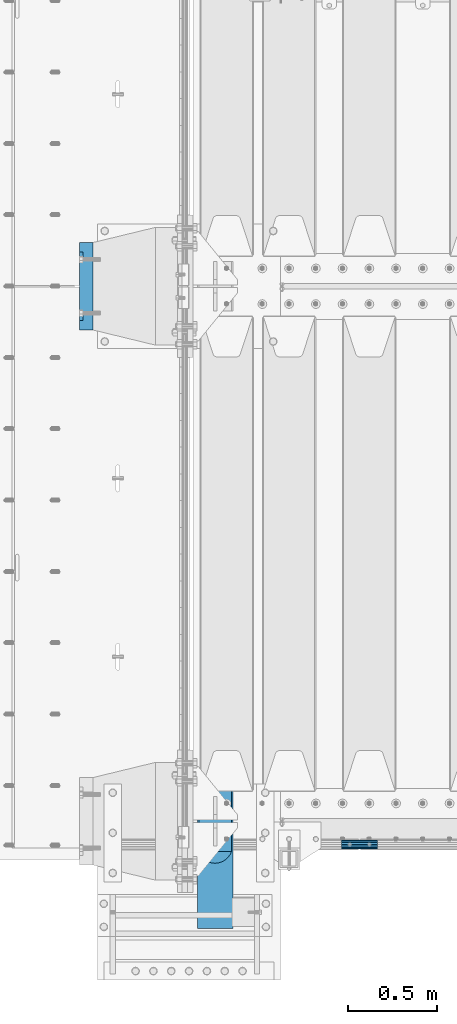
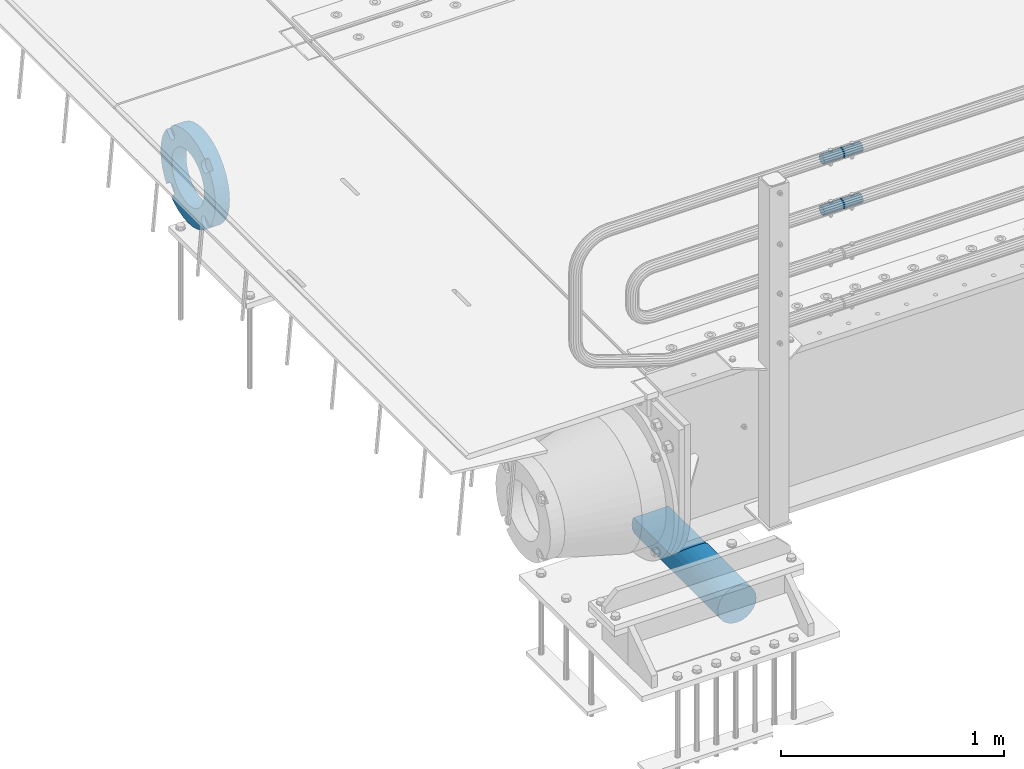
# One storey, part 114 of 208: 4 beams.
"""IFC2X3 building model written with IfcOpenShell, lengths in millimetres."""

from ifc_helpers import new_model, si_unit, frame, origin_with_axes, place, context, subcontext, project, spatial, faceted_brep, material, type_object, element, save


model = new_model("IFC2X3")

# Units and contexts
model_context = context("Model", 3, precision=1e-05, world=origin_with_axes())
body_context = subcontext(model_context, "Body", "Model", "MODEL_VIEW")
ifc_project = project(units=[si_unit("LENGTHUNIT", "METRE", prefix="MILLI"), si_unit("AREAUNIT", "SQUARE_METRE"), si_unit("VOLUMEUNIT", "CUBIC_METRE"), si_unit("MASSUNIT", "GRAM", prefix="KILO"), si_unit("TIMEUNIT", "SECOND"), si_unit("PLANEANGLEUNIT", "RADIAN"), si_unit("SOLIDANGLEUNIT", "STERADIAN"), si_unit("THERMODYNAMICTEMPERATUREUNIT", "DEGREE_CELSIUS"), si_unit("LUMINOUSINTENSITYUNIT", "LUMEN")], contexts=[model_context])

# Site, building, storey
site_placement = place(None, origin_with_axes())
site = spatial("IfcSite", under=ifc_project, at=site_placement, CompositionType="ELEMENT")
building_placement = place(site_placement, origin_with_axes())
building = spatial("IfcBuilding", under=site, at=building_placement, Name="Standard", CompositionType="ELEMENT")
storey_placement = place(building_placement, origin_with_axes())
storey = spatial("IfcBuildingStorey", under=building, at=storey_placement, Name="Undefined", CompositionType="ELEMENT", Elevation=0.0)

# Beams
ifc_material_1 = material(Name="STEEL/S355N")
beam_type_1 = type_object("IfcBeamType", Name="D200", PredefinedType="NOTDEFINED")
beam_1_placement = place(storey_placement, frame((-42315.0, -600.0, -928.0), z_axis=(0.0, 0.0, 1.0), x_axis=(0.0, 1.0, 0.0)))
element("IfcBeam", 1, at=beam_1_placement, inside=storey, type_object=beam_type_1, material=ifc_material_1, ObjectType="D200", context=body_context, shape_type="Brep", body=[
    faceted_brep([(417.294117647059, 86.6025403784442, 50.0), (395.365164344953, 70.7106781186521, 70.7106781186548), (378.538486658119, 50.0, 86.6025403784439), (367.96079486351, 25.88190451025, 96.5925826289068), (364.35294117647, 0.0, 100.0), (367.96079486351, -25.88190451025, 96.5925826289068), (378.538486658119, -50.0, 86.6025403784439), (395.365164344953, -70.7106781186521, 70.7106781186548), (417.294117647059, -86.6025403784442, 50.0), (430.0, -91.5731031269243, 38.0), (430.0, 91.573103126917, 38.0), (770.0, -91.5731031269243, 37.9999999999994), (770.0, 91.5731031269243, 37.9999999999994), (0.0, -96.5925826289094, 25.8819045102521), (0.0, -86.6025403784442, 50.0), (0.0, -70.7106781186521, 70.7106781186548), (0.0, -50.0, 86.6025403784439), (0.0, -25.88190451025, 96.5925826289068), (0.0, 0.0, 100.0), (0.0, 25.88190451025, 96.5925826289068), (0.0, 50.0, 86.6025403784439), (0.0, 70.7106781186521, 70.7106781186548), (0.0, 86.6025403784442, 50.0), (0.0, 96.5925826289094, 25.8819045102521), (0.0, 100.0, 0.0), (0.0, 96.5925826289094, -25.8819045102521), (0.0, 86.6025403784442, -50.0), (0.0, 70.7106781186521, -70.7106781186548), (0.0, 50.0, -86.6025403784438), (0.0, 25.88190451025, -96.5925826289067), (0.0, 0.0, -100.0), (0.0, -25.88190451025, -96.5925826289069), (0.0, -50.0, -86.6025403784439), (0.0, -70.7106781186521, -70.7106781186548), (0.0, -86.6025403784442, -50.0), (0.0, -96.5925826289094, -25.8819045102522), (0.0, -100.0, 0.0), (770.0, 96.5925826289094, 25.8819045102521), (770.0, 100.0, 0.0), (770.0, 96.5925826289094, -25.8819045102521), (770.0, 86.6025403784442, -50.0), (770.0, 70.7106781186521, -70.7106781186548), (770.0, 50.0, -86.6025403784438), (770.0, 25.88190451025, -96.5925826289067), (770.0, 0.0, -100.0), (770.0, -25.88190451025, -96.5925826289069), (770.0, -50.0, -86.6025403784439), (770.0, -70.7106781186521, -70.7106781186548), (770.0, -86.6025403784442, -50.0), (770.0, -96.5925826289094, -25.8819045102522), (770.0, -100.0, 0.0), (770.0, -96.5925826289094, 25.8819045102521)], [[[0, 1, 2, 3, 4, 5, 6, 7, 8, 9, 10]], [[10, 9, 11, 12]], [[13, 14, 15, 16, 17, 18, 19, 20, 21, 22, 23, 24, 25, 26, 27, 28, 29, 30, 31, 32, 33, 34, 35, 36]], [[24, 23, 37, 38]], [[25, 24, 38, 39]], [[26, 25, 39, 40]], [[27, 26, 40, 41]], [[28, 27, 41, 42]], [[29, 28, 42, 43]], [[30, 29, 43, 44]], [[31, 30, 44, 45]], [[32, 31, 45, 46]], [[33, 32, 46, 47]], [[34, 33, 47, 48]], [[35, 34, 48, 49]], [[36, 35, 49, 50]], [[13, 36, 50, 51]], [[14, 13, 51, 11, 9, 8]], [[15, 14, 8, 7]], [[16, 15, 7, 6]], [[17, 16, 6, 5]], [[18, 17, 5, 4]], [[19, 18, 4, 3]], [[20, 19, 3, 2]], [[21, 20, 2, 1]], [[22, 21, 1, 0]], [[37, 23, 22, 0, 10, 12]], [[51, 50, 49, 48, 47, 46, 45, 44, 43, 42, 41, 40, 39, 38, 37, 12, 11]]]),
])
ifc_material_2 = material()
beam_type_2 = type_object("IfcBeamType", PredefinedType="NOTDEFINED")
beam_2_placement = place(storey_placement, frame((-41605.0024970001, -129.849999999603, 969.849999999725), z_axis=(0.0, 0.0, 1.0), x_axis=(1.0, 0.0, 0.0)))
element("IfcBeam", 2, at=beam_2_placement, inside=storey, type_object=beam_type_2, material=ifc_material_2, context=body_context, shape_type="Brep", body=[
    faceted_brep([(0.0, -21.8999999999996, 0.0), (0.0, -20.2329617619971, 8.38076716879547), (200.0, -20.2329617619971, 8.38076716879547), (200.0, -21.8999999999996, 0.0), (0.0, -15.4856385079856, 15.4856385079854), (200.0, -15.4856385079856, 15.4856385079854), (0.0, -8.3807671687955, 20.2329617619972), (200.0, -8.3807671687955, 20.2329617619972), (0.0, 0.0, 21.9), (200.0, 0.0, 21.9), (0.0, 8.3807671687955, 20.2329617619972), (200.0, 8.3807671687955, 20.2329617619972), (0.0, 15.4856385079856, 15.4856385079854), (200.0, 15.4856385079856, 15.4856385079854), (0.0, 20.2329617619971, 8.38076716879547), (200.0, 20.2329617619971, 8.38076716879547), (0.0, 21.8999999999996, 0.0), (200.0, 21.8999999999996, 0.0), (0.0, 20.2329617619971, -8.38076716879547), (200.0, 20.2329617619971, -8.38076716879547), (0.0, 15.4856385079856, -15.4856385079854), (200.0, 15.4856385079856, -15.4856385079854), (0.0, 8.3807671687955, -20.2329617619972), (200.0, 8.3807671687955, -20.2329617619972), (0.0, 0.0, -21.9), (200.0, 0.0, -21.9), (0.0, -8.3807671687955, -20.2329617619972), (200.0, -8.3807671687955, -20.2329617619972), (0.0, -15.4856385079856, -15.4856385079854), (200.0, -15.4856385079856, -15.4856385079854), (0.0, -20.2329617619971, -8.38076716879547), (200.0, -20.2329617619971, -8.38076716879547), (0.0, -25.5, 0.0), (0.0, -23.5589280790382, -9.7584275253098), (200.0, -23.5589280790382, -9.7584275253098), (200.0, -25.5, 0.0), (0.0, -18.0312229202573, -18.031222920257), (200.0, -18.0312229202573, -18.031222920257), (0.0, -9.75842752530934, -23.5589280790378), (200.0, -9.75842752530934, -23.5589280790378), (0.0, 0.0, -25.5), (200.0, 0.0, -25.5), (0.0, 9.75842752531025, -23.5589280790378), (200.0, 9.75842752531025, -23.5589280790378), (0.0, 18.0312229202573, -18.031222920257), (200.0, 18.0312229202573, -18.031222920257), (0.0, 23.5589280790382, -9.7584275253098), (200.0, 23.5589280790382, -9.7584275253098), (0.0, 25.5, 0.0), (200.0, 25.5, 0.0), (0.0, 23.5589280790382, 9.7584275253098), (200.0, 23.5589280790382, 9.7584275253098), (0.0, 18.0312229202573, 18.031222920257), (200.0, 18.0312229202573, 18.031222920257), (0.0, 9.75842752530934, 23.5589280790378), (200.0, 9.75842752530934, 23.5589280790378), (0.0, 0.0, 25.5), (200.0, 0.0, 25.5), (0.0, -9.75842752530934, 23.5589280790378), (200.0, -9.75842752530934, 23.5589280790378), (0.0, -18.0312229202573, 18.031222920257), (200.0, -18.0312229202573, 18.031222920257), (0.0, -23.5589280790382, 9.7584275253098), (200.0, -23.5589280790382, 9.7584275253098)], [[[0, 1, 2, 3]], [[1, 4, 5, 2]], [[4, 6, 7, 5]], [[6, 8, 9, 7]], [[8, 10, 11, 9]], [[10, 12, 13, 11]], [[12, 14, 15, 13]], [[14, 16, 17, 15]], [[16, 18, 19, 17]], [[18, 20, 21, 19]], [[20, 22, 23, 21]], [[22, 24, 25, 23]], [[24, 26, 27, 25]], [[26, 28, 29, 27]], [[28, 30, 31, 29]], [[30, 0, 3, 31]], [[32, 33, 34, 35]], [[33, 36, 37, 34]], [[36, 38, 39, 37]], [[38, 40, 41, 39]], [[40, 42, 43, 41]], [[42, 44, 45, 43]], [[44, 46, 47, 45]], [[46, 48, 49, 47]], [[48, 50, 51, 49]], [[50, 52, 53, 51]], [[52, 54, 55, 53]], [[54, 56, 57, 55]], [[56, 58, 59, 57]], [[58, 60, 61, 59]], [[60, 62, 63, 61]], [[62, 32, 35, 63]], [[37, 39, 41, 43, 45, 47, 49, 51, 53, 55, 57, 59, 61, 63, 35, 34], [5, 7, 9, 11, 13, 15, 17, 19, 21, 23, 25, 27, 29, 31, 3, 2]], [[62, 60, 58, 56, 54, 52, 50, 48, 46, 44, 42, 40, 38, 36, 33, 32], [30, 28, 26, 24, 22, 20, 18, 16, 14, 12, 10, 8, 6, 4, 1, 0]]]),
])
beam_3_placement = place(storey_placement, frame((-41605.0024970001, -129.849999999603, 689.849999999725), z_axis=(0.0, 0.0, 1.0), x_axis=(1.0, 0.0, 0.0)))
element("IfcBeam", 3, at=beam_3_placement, inside=storey, type_object=beam_type_2, material=ifc_material_2, context=body_context, shape_type="Brep", body=[
    faceted_brep([(0.0, -21.8999999999996, 0.0), (0.0, -20.2329617619971, 8.38076716879547), (200.0, -20.2329617619971, 8.38076716879547), (200.0, -21.8999999999996, 0.0), (0.0, -15.4856385079856, 15.4856385079854), (200.0, -15.4856385079856, 15.4856385079854), (0.0, -8.3807671687955, 20.2329617619972), (200.0, -8.3807671687955, 20.2329617619972), (0.0, 0.0, 21.9), (200.0, 0.0, 21.9), (0.0, 8.3807671687955, 20.2329617619972), (200.0, 8.3807671687955, 20.2329617619972), (0.0, 15.4856385079856, 15.4856385079854), (200.0, 15.4856385079856, 15.4856385079854), (0.0, 20.2329617619971, 8.38076716879547), (200.0, 20.2329617619971, 8.38076716879547), (0.0, 21.8999999999996, 0.0), (200.0, 21.8999999999996, 0.0), (0.0, 20.2329617619971, -8.38076716879547), (200.0, 20.2329617619971, -8.38076716879547), (0.0, 15.4856385079856, -15.4856385079854), (200.0, 15.4856385079856, -15.4856385079854), (0.0, 8.3807671687955, -20.2329617619972), (200.0, 8.3807671687955, -20.2329617619972), (0.0, 0.0, -21.9), (200.0, 0.0, -21.9), (0.0, -8.3807671687955, -20.2329617619972), (200.0, -8.3807671687955, -20.2329617619972), (0.0, -15.4856385079856, -15.4856385079854), (200.0, -15.4856385079856, -15.4856385079854), (0.0, -20.2329617619971, -8.38076716879547), (200.0, -20.2329617619971, -8.38076716879547), (0.0, -25.5, 0.0), (0.0, -23.5589280790382, -9.7584275253098), (200.0, -23.5589280790382, -9.7584275253098), (200.0, -25.5, 0.0), (0.0, -18.0312229202573, -18.031222920257), (200.0, -18.0312229202573, -18.031222920257), (0.0, -9.75842752530934, -23.5589280790378), (200.0, -9.75842752530934, -23.5589280790378), (0.0, 0.0, -25.5), (200.0, 0.0, -25.5), (0.0, 9.75842752531025, -23.5589280790378), (200.0, 9.75842752531025, -23.5589280790378), (0.0, 18.0312229202573, -18.031222920257), (200.0, 18.0312229202573, -18.031222920257), (0.0, 23.5589280790382, -9.7584275253098), (200.0, 23.5589280790382, -9.7584275253098), (0.0, 25.5, 0.0), (200.0, 25.5, 0.0), (0.0, 23.5589280790382, 9.7584275253098), (200.0, 23.5589280790382, 9.7584275253098), (0.0, 18.0312229202573, 18.031222920257), (200.0, 18.0312229202573, 18.031222920257), (0.0, 9.75842752530934, 23.5589280790378), (200.0, 9.75842752530934, 23.5589280790378), (0.0, 0.0, 25.5), (200.0, 0.0, 25.5), (0.0, -9.75842752530934, 23.5589280790378), (200.0, -9.75842752530934, 23.5589280790378), (0.0, -18.0312229202573, 18.031222920257), (200.0, -18.0312229202573, 18.031222920257), (0.0, -23.5589280790382, 9.7584275253098), (200.0, -23.5589280790382, 9.7584275253098)], [[[0, 1, 2, 3]], [[1, 4, 5, 2]], [[4, 6, 7, 5]], [[6, 8, 9, 7]], [[8, 10, 11, 9]], [[10, 12, 13, 11]], [[12, 14, 15, 13]], [[14, 16, 17, 15]], [[16, 18, 19, 17]], [[18, 20, 21, 19]], [[20, 22, 23, 21]], [[22, 24, 25, 23]], [[24, 26, 27, 25]], [[26, 28, 29, 27]], [[28, 30, 31, 29]], [[30, 0, 3, 31]], [[32, 33, 34, 35]], [[33, 36, 37, 34]], [[36, 38, 39, 37]], [[38, 40, 41, 39]], [[40, 42, 43, 41]], [[42, 44, 45, 43]], [[44, 46, 47, 45]], [[46, 48, 49, 47]], [[48, 50, 51, 49]], [[50, 52, 53, 51]], [[52, 54, 55, 53]], [[54, 56, 57, 55]], [[56, 58, 59, 57]], [[58, 60, 61, 59]], [[60, 62, 63, 61]], [[62, 32, 35, 63]], [[37, 39, 41, 43, 45, 47, 49, 51, 53, 55, 57, 59, 61, 63, 35, 34], [5, 7, 9, 11, 13, 15, 17, 19, 21, 23, 25, 27, 29, 31, 3, 2]], [[62, 60, 58, 56, 54, 52, 50, 48, 46, 44, 42, 40, 38, 36, 33, 32], [30, 28, 26, 24, 22, 20, 18, 16, 14, 12, 10, 8, 6, 4, 1, 0]]]),
])
ifc_material_3 = material(Name="SCN-500-E2")
beam_type_3 = type_object("IfcBeamType", PredefinedType="NOTDEFINED")
beam_4_placement = place(storey_placement, frame((-43000.0, 3000.00000146624, -515.0), z_axis=(0.0, 0.0, 1.0), x_axis=(-1.0, 0.0, 0.0)))
element("IfcBeam", 4, at=beam_4_placement, inside=storey, type_object=beam_type_3, material=ifc_material_3, context=body_context, shape_type="Brep", body=[
    faceted_brep([(75.0, 192.717024793295, -150.290616455866), (75.0, 171.473395903973, -129.046987566545), (55.0, 171.473395903973, -129.046987566545), (55.0, 192.717024793295, -150.290616455866), (75.0, 167.467485558908, -125.685629673471), (55.0, 167.467485558908, -125.685629673471), (75.0, 162.938740320598, -123.070957391042), (55.0, 162.938740320598, -123.070957391042), (75.0, 158.024763821452, -121.282416213469), (55.0, 158.024763821452, -121.282416213469), (75.0, 152.874864750806, -120.374350059389), (55.0, 152.874864750806, -120.374350059389), (75.0, 147.645520185947, -120.374350059389), (55.0, 147.645520185947, -120.374350059389), (75.0, 142.495621115301, -121.282416213469), (55.0, 142.495621115301, -121.282416213469), (75.0, 137.581644616156, -123.070957391042), (55.0, 137.581644616156, -123.070957391042), (75.0, 133.052899377845, -125.685629673471), (55.0, 133.052899377845, -125.685629673471), (75.0, 129.04698903278, -129.046987566545), (55.0, 129.04698903278, -129.046987566545), (75.0, 125.685631139707, -133.05289791161), (55.0, 125.685631139707, -133.05289791161), (75.0, 123.070958857277, -137.58164314992), (55.0, 123.070958857277, -137.58164314992), (75.0, 121.282417679705, -142.495619649066), (55.0, 121.282417679705, -142.495619649066), (75.0, 120.374351525625, -147.645518719712), (55.0, 120.374351525625, -147.645518719712), (75.0, 120.374351525625, -152.874863284571), (55.0, 120.374351525625, -152.874863284571), (75.0, 121.282417679705, -158.024762355217), (55.0, 121.282417679705, -158.024762355217), (75.0, 123.070958857277, -162.938738854362), (55.0, 123.070958857277, -162.938738854362), (75.0, 125.685631139707, -167.467484092673), (55.0, 125.685631139707, -167.467484092673), (75.0, 129.04698903278, -171.473394437738), (55.0, 129.04698903278, -171.473394437738), (55.0, 150.290618180638, -192.717023585596), (75.0, 150.290618180639, -192.717023585596), (55.0, 157.482964373202, -187.68088856415), (55.0, 187.680888564149, -157.482964373202), (75.0, -192.717023585596, 150.29061818064), (75.0, -171.4733929715, 129.046987566545), (55.0, -171.4733929715, 129.046987566545), (55.0, -192.717023585596, 150.29061818064), (75.0, -167.467482626435, 125.685629673472), (55.0, -167.467482626435, 125.685629673472), (75.0, -162.938737388125, 123.070957391042), (55.0, -162.938737388125, 123.070957391042), (75.0, -158.024760888979, 121.282416213469), (55.0, -158.024760888979, 121.282416213469), (75.0, -152.874861818334, 120.374350059389), (55.0, -152.874861818334, 120.374350059389), (75.0, -147.645517253474, 120.374350059389), (55.0, -147.645517253474, 120.374350059389), (75.0, -142.495618182828, 121.282416213469), (55.0, -142.495618182828, 121.282416213469), (75.0, -137.581641683683, 123.070957391042), (55.0, -137.581641683683, 123.070957391042), (75.0, -133.052896445372, 125.685629673472), (55.0, -133.052896445372, 125.685629673472), (75.0, -129.046986100308, 129.046987566545), (55.0, -129.046986100308, 129.046987566545), (75.0, -125.685628207234, 133.05289791161), (55.0, -125.685628207234, 133.05289791161), (75.0, -123.070955924804, 137.58164314992), (55.0, -123.070955924804, 137.58164314992), (75.0, -121.282414747232, 142.495619649066), (55.0, -121.282414747232, 142.495619649066), (75.0, -120.374348593152, 147.645518719712), (55.0, -120.374348593152, 147.645518719712), (75.0, -120.374348593152, 152.874863284571), (55.0, -120.374348593152, 152.874863284571), (75.0, -121.282414747232, 158.024762355217), (55.0, -121.282414747232, 158.024762355217), (75.0, -123.070955924804, 162.938738854362), (55.0, -123.070955924804, 162.938738854362), (75.0, -125.685628207234, 167.467484092673), (55.0, -125.685628207234, 167.467484092673), (75.0, -129.046986100308, 171.473394437738), (55.0, -129.046986100308, 171.473394437738), (55.0, -150.290616455865, 192.717024793295), (75.0, -150.290616455866, 192.717024793295), (75.0, 150.290618180638, 192.717023585596), (75.0000000000073, 129.04698903278, 171.473394437739), (55.0, 129.04698903278, 171.473394437739), (55.0, 150.290618180638, 192.717023585597), (75.0000000000073, 125.685631139707, 167.467484092674), (55.0, 125.685631139707, 167.467484092674), (75.0000000000073, 123.070958857277, 162.938738854364), (55.0, 123.070958857277, 162.938738854364), (75.0000000000073, 121.282417679705, 158.024762355218), (55.0, 121.282417679705, 158.024762355218), (75.0000000000073, 120.374351525625, 152.874863284572), (55.0, 120.374351525625, 152.874863284572), (75.0000000000073, 120.374351525625, 147.645518719713), (55.0, 120.374351525625, 147.645518719713), (75.0000000000073, 121.282417679705, 142.495619649067), (55.0, 121.282417679705, 142.495619649067), (75.0000000000073, 123.070958857277, 137.581643149922), (55.0, 123.070958857277, 137.581643149922), (75.0000000000073, 125.685631139707, 133.052897911611), (55.0, 125.685631139707, 133.052897911611), (75.0000000000073, 129.04698903278, 129.046987566546), (55.0, 129.04698903278, 129.046987566546), (75.0000000000073, 133.052899377845, 125.685629673473), (55.0, 133.052899377845, 125.685629673473), (75.0000000000073, 137.581644616156, 123.070957391043), (55.0, 137.581644616156, 123.070957391043), (75.0000000000073, 142.495621115301, 121.282416213471), (55.0, 142.495621115301, 121.282416213471), (75.0000000000073, 147.645520185947, 120.37435005939), (55.0, 147.645520185947, 120.37435005939), (75.0000000000073, 152.874864750806, 120.37435005939), (55.0, 152.874864750806, 120.37435005939), (75.0000000000073, 158.024763821452, 121.282416213471), (55.0, 158.024763821452, 121.282416213471), (75.0000000000073, 162.938740320597, 123.070957391043), (55.0, 162.938740320597, 123.070957391043), (75.0000000000073, 167.467485558908, 125.685629673473), (55.0, 167.467485558908, 125.685629673473), (75.0000000000073, 171.473395903973, 129.046987566546), (55.0, 171.473395903973, 129.046987566546), (55.0, 192.717024793295, 150.290616455867), (75.0, 192.717024793294, 150.290616455868), (0.0, 212.176223927187, -122.5), (0.0, 230.224692092547, -83.7949351147888), (75.0, 230.224692092547, -83.7949351147888), (75.0, 212.176223927187, -122.5), (0.0, 241.277899487991, -42.5438035283978), (75.0, 241.277899487991, -42.5438035283978), (0.0, 245.0, 0.0), (75.0, 245.0, 0.0), (0.0, 241.277899487991, 42.543803528398), (75.0, 241.277899487991, 42.543803528398), (0.0, 230.224692092547, 83.7949351147889), (75.0, 230.224692092547, 83.7949351147889), (0.0, 212.176223927187, 122.5), (75.0, 212.176223927187, 122.5), (0.0, 187.680888564149, 157.482964373202), (55.0, 187.680888564149, 157.482964373202), (0.0, 157.482964373202, 187.68088856415), (55.0, 157.482964373202, 187.68088856415), (0.0, 122.5, 212.176223927187), (75.0, 122.5, 212.176223927187), (0.0, 83.794935114789, 230.224692092548), (75.0, 83.794935114789, 230.224692092548), (0.0, 42.5438035283978, 241.277899487991), (75.0, 42.5438035283978, 241.277899487991), (0.0, 0.0, 245.0), (75.0, 0.0, 245.0), (0.0, -42.5438035283978, 241.277899487991), (75.0, -42.5438035283978, 241.277899487991), (0.0, -83.794935114789, 230.224692092548), (75.0, -83.794935114789, 230.224692092548), (0.0, -122.5, 212.176223927187), (75.0, -122.5, 212.176223927187), (0.0, -157.482964373202, 187.68088856415), (55.0, -157.482964373202, 187.68088856415), (0.0, -187.680888564149, 157.482964373202), (55.0, -187.680888564149, 157.482964373202), (0.0, -212.176223927187, 122.5), (75.0, -212.176223927187, 122.5), (0.0, -230.224692092547, 83.7949351147888), (75.0, -230.224692092547, 83.7949351147888), (0.0, -241.277899487991, 42.5438035283979), (75.0, -241.277899487991, 42.5438035283979), (0.0, -245.0, 0.0), (75.0, -245.0, 0.0), (0.0, -187.680888564149, -157.482964373202), (0.0, -157.482964373202, -187.68088856415), (55.0, -157.482964373202, -187.68088856415), (55.0, -187.680888564149, -157.482964373202), (0.0, 83.794935114789, -230.224692092547), (0.0, 122.5, -212.176223927187), (75.0, 122.5, -212.176223927187), (75.0, 83.794935114789, -230.224692092547), (0.0, 42.5438035283978, -241.277899487991), (75.0, 42.5438035283978, -241.277899487991), (0.0, 0.0, -245.0), (75.0, 0.0, -245.0), (0.0, -42.5438035283978, -241.277899487991), (75.0, -42.5438035283978, -241.277899487991), (0.0, -83.794935114789, -230.224692092548), (75.0, -83.794935114789, -230.224692092548), (0.0, -122.5, -212.176223927187), (75.0, -122.5, -212.176223927187), (75.0, -150.290616455864, -192.717024793296), (55.0, -150.290616455864, -192.717024793296), (55.0, -129.046986100308, -171.473394437739), (55.0, -125.685628207234, -167.467484092674), (55.0, -123.070955924804, -162.938738854364), (55.0, -121.282414747232, -158.024762355218), (55.0, -120.374348593152, -152.874863284572), (55.0, -120.374348593152, -147.645518719713), (55.0, -121.282414747232, -142.495619649067), (55.0, -123.070955924804, -137.581643149922), (55.0, -125.685628207234, -133.052897911611), (55.0, -129.046986100308, -129.046987566546), (55.0, -133.052896445372, -125.685629673473), (55.0, -137.581641683683, -123.070957391043), (55.0, -142.495618182828, -121.282416213471), (55.0, -147.645517253474, -120.37435005939), (55.0, -152.874861818334, -120.37435005939), (55.0, -158.024760888979, -121.282416213471), (55.0, -162.938737388125, -123.070957391043), (55.0, -167.467482626435, -125.685629673473), (55.0, -171.4733929715, -129.046987566546), (55.0, -192.717023585595, -150.29061818064), (75.0, -129.046986100308, -171.473394437739), (75.0, -125.685628207234, -167.467484092674), (75.0, -123.070955924804, -162.938738854364), (75.0, -121.282414747232, -158.024762355218), (75.0, -120.374348593152, -152.874863284572), (75.0, -120.374348593152, -147.645518719713), (75.0, -121.282414747232, -142.495619649067), (75.0, -123.070955924804, -137.581643149922), (75.0, -125.685628207234, -133.052897911611), (75.0, -129.046986100308, -129.046987566546), (75.0, -133.052896445372, -125.685629673473), (75.0, -137.581641683683, -123.070957391043), (75.0, -142.495618182828, -121.282416213471), (75.0, -147.645517253474, -120.37435005939), (75.0, -152.874861818334, -120.37435005939), (75.0, -158.024760888979, -121.282416213471), (75.0, -162.938737388125, -123.070957391043), (75.0, -167.467482626435, -125.685629673473), (75.0, -171.4733929715, -129.046987566546), (75.0, -192.717023585595, -150.290618180641), (75.0, -212.176223927187, -122.5), (0.0, -212.176223927187, -122.5), (0.0, -230.224692092547, -83.794935114789), (75.0, -230.224692092547, -83.794935114789), (0.0, -241.277899487991, -42.5438035283979), (75.0, -241.277899487991, -42.5438035283979), (0.0, 187.680888564149, -157.482964373202), (0.0, 157.482964373202, -187.68088856415), (0.0, -142.79712418677, -25.1789857617049), (0.0, -136.255430013956, -49.592920782222), (0.0, -125.573683548743, -72.5), (0.0, -111.076444252252, -93.2042034045483), (0.0, -93.204203404548, -111.076444252252), (0.0, -72.5, -125.573683548744), (0.0, -49.5929207822219, -136.255430013957), (0.0, -25.178985761705, -142.79712418677), (0.0, 0.0, -145.0), (0.0, 25.178985761705, -142.79712418677), (0.0, 49.5929207822219, -136.255430013957), (0.0, 72.5, -125.573683548744), (0.0, 93.204203404548, -111.076444252252), (0.0, 111.076444252251, -93.2042034045483), (0.0, 125.573683548743, -72.5), (0.0, 136.255430013956, -49.592920782222), (0.0, 142.79712418677, -25.178985761705), (0.0, 145.0, 0.0), (0.0, 142.79712418677, 25.1789857617048), (0.0, 136.255430013956, 49.5929207822219), (0.0, 125.573683548743, 72.4999999999999), (0.0, 111.076444252252, 93.2042034045482), (0.0, 93.204203404548, 111.076444252252), (0.0, 72.5, 125.573683548744), (0.0, 49.5929207822219, 136.255430013957), (0.0, 25.178985761705, 142.79712418677), (0.0, 0.0, 145.0), (0.0, -25.178985761705, 142.79712418677), (0.0, -49.5929207822219, 136.255430013957), (0.0, -72.5, 125.573683548744), (0.0, -93.204203404548, 111.076444252252), (0.0, -111.076444252251, 93.2042034045483), (0.0, -125.573683548743, 72.5000000000001), (0.0, -136.255430013956, 49.5929207822221), (0.0, -142.79712418677, 25.1789857617049), (0.0, -145.0, 0.0), (75.0, -145.0, 0.0), (75.0, -142.79712418677, -25.1789857617049), (75.0, -136.255430013956, -49.592920782222), (75.0, -125.573683548743, -72.5), (75.0, -111.076444252252, -93.2042034045483), (75.0, -93.204203404548, -111.076444252252), (75.0, -72.5, -125.573683548744), (75.0, -49.5929207822219, -136.255430013957), (75.0, -25.178985761705, -142.79712418677), (75.0, 0.0, -145.0), (75.0, 25.178985761705, -142.79712418677), (75.0, 49.5929207822219, -136.255430013957), (75.0, 72.5, -125.573683548744), (75.0, 93.204203404548, -111.076444252252), (75.0, 111.076444252251, -93.2042034045483), (75.0, 125.573683548743, -72.5), (75.0, 136.255430013956, -49.592920782222), (75.0, 142.79712418677, -25.178985761705), (75.0, 145.0, 0.0), (75.0, 142.79712418677, 25.1789857617048), (75.0, 136.255430013956, 49.5929207822219), (75.0, 125.573683548743, 72.4999999999999), (75.0, 111.076444252252, 93.2042034045482), (75.0, 93.204203404548, 111.076444252252), (75.0, 72.5, 125.573683548744), (75.0, 49.5929207822219, 136.255430013957), (75.0, 25.178985761705, 142.79712418677), (75.0, 0.0, 145.0), (75.0, -25.178985761705, 142.79712418677), (75.0, -49.5929207822219, 136.255430013957), (75.0, -72.5, 125.573683548744), (75.0, -93.204203404548, 111.076444252252), (75.0, -111.076444252251, 93.2042034045483), (75.0, -125.573683548743, 72.5000000000001), (75.0, -136.255430013956, 49.5929207822221), (75.0, -142.79712418677, 25.1789857617049)], [[[0, 1, 2, 3]], [[4, 5, 2, 1]], [[6, 7, 5, 4]], [[8, 9, 7, 6]], [[10, 11, 9, 8]], [[12, 13, 11, 10]], [[14, 15, 13, 12]], [[16, 17, 15, 14]], [[18, 19, 17, 16]], [[20, 21, 19, 18]], [[22, 23, 21, 20]], [[24, 25, 23, 22]], [[26, 27, 25, 24]], [[28, 29, 27, 26]], [[30, 31, 29, 28]], [[32, 33, 31, 30]], [[34, 35, 33, 32]], [[36, 37, 35, 34]], [[38, 39, 37, 36]], [[40, 39, 38, 41]], [[42, 43, 3, 2, 5, 7, 9, 11, 13, 15, 17, 19, 21, 23, 25, 27, 29, 31, 33, 35, 37, 39, 40]], [[44, 45, 46, 47]], [[48, 49, 46, 45]], [[50, 51, 49, 48]], [[52, 53, 51, 50]], [[54, 55, 53, 52]], [[56, 57, 55, 54]], [[58, 59, 57, 56]], [[60, 61, 59, 58]], [[62, 63, 61, 60]], [[64, 65, 63, 62]], [[66, 67, 65, 64]], [[68, 69, 67, 66]], [[70, 71, 69, 68]], [[72, 73, 71, 70]], [[74, 75, 73, 72]], [[76, 77, 75, 74]], [[78, 79, 77, 76]], [[80, 81, 79, 78]], [[82, 83, 81, 80]], [[84, 83, 82, 85]], [[86, 87, 88, 89]], [[90, 91, 88, 87]], [[92, 93, 91, 90]], [[94, 95, 93, 92]], [[96, 97, 95, 94]], [[98, 99, 97, 96]], [[100, 101, 99, 98]], [[102, 103, 101, 100]], [[104, 105, 103, 102]], [[106, 107, 105, 104]], [[108, 109, 107, 106]], [[110, 111, 109, 108]], [[112, 113, 111, 110]], [[114, 115, 113, 112]], [[116, 117, 115, 114]], [[118, 119, 117, 116]], [[120, 121, 119, 118]], [[122, 123, 121, 120]], [[124, 125, 123, 122]], [[126, 125, 124, 127]], [[128, 129, 130, 131]], [[129, 132, 133, 130]], [[132, 134, 135, 133]], [[134, 136, 137, 135]], [[136, 138, 139, 137]], [[138, 140, 141, 139]], [[127, 141, 140, 142, 143, 126]], [[142, 144, 145, 143]], [[89, 88, 91, 93, 95, 97, 99, 101, 103, 105, 107, 109, 111, 113, 115, 117, 119, 121, 123, 125, 126, 143, 145]], [[144, 146, 147, 86, 89, 145]], [[146, 148, 149, 147]], [[148, 150, 151, 149]], [[150, 152, 153, 151]], [[152, 154, 155, 153]], [[154, 156, 157, 155]], [[156, 158, 159, 157]], [[85, 159, 158, 160, 161, 84]], [[160, 162, 163, 161]], [[47, 46, 49, 51, 53, 55, 57, 59, 61, 63, 65, 67, 69, 71, 73, 75, 77, 79, 81, 83, 84, 161, 163]], [[162, 164, 165, 44, 47, 163]], [[164, 166, 167, 165]], [[166, 168, 169, 167]], [[168, 170, 171, 169]], [[172, 173, 174, 175]], [[176, 177, 178, 179]], [[180, 176, 179, 181]], [[182, 180, 181, 183]], [[184, 182, 183, 185]], [[186, 184, 185, 187]], [[188, 186, 187, 189]], [[173, 188, 189, 190, 191, 174]], [[175, 174, 191, 192, 193, 194, 195, 196, 197, 198, 199, 200, 201, 202, 203, 204, 205, 206, 207, 208, 209, 210, 211]], [[190, 212, 192, 191]], [[213, 193, 192, 212]], [[214, 194, 193, 213]], [[215, 195, 194, 214]], [[216, 196, 195, 215]], [[217, 197, 196, 216]], [[218, 198, 197, 217]], [[219, 199, 198, 218]], [[220, 200, 199, 219]], [[221, 201, 200, 220]], [[222, 202, 201, 221]], [[223, 203, 202, 222]], [[224, 204, 203, 223]], [[225, 205, 204, 224]], [[226, 206, 205, 225]], [[227, 207, 206, 226]], [[228, 208, 207, 227]], [[229, 209, 208, 228]], [[230, 210, 209, 229]], [[211, 210, 230, 231]], [[232, 233, 172, 175, 211, 231]], [[234, 233, 232, 235]], [[236, 234, 235, 237]], [[170, 236, 237, 171]], [[168, 166, 164, 162, 160, 158, 156, 154, 152, 150, 148, 146, 144, 142, 140, 138, 136, 134, 132, 129, 128, 238, 239, 177, 176, 180, 182, 184, 186, 188, 173, 172, 233, 234, 236, 170], [240, 241, 242, 243, 244, 245, 246, 247, 248, 249, 250, 251, 252, 253, 254, 255, 256, 257, 258, 259, 260, 261, 262, 263, 264, 265, 266, 267, 268, 269, 270, 271, 272, 273, 274, 275]], [[240, 275, 276, 277]], [[241, 240, 277, 278]], [[242, 241, 278, 279]], [[243, 242, 279, 280]], [[244, 243, 280, 281]], [[245, 244, 281, 282]], [[246, 245, 282, 283]], [[247, 246, 283, 284]], [[248, 247, 284, 285]], [[249, 248, 285, 286]], [[250, 249, 286, 287]], [[251, 250, 287, 288]], [[252, 251, 288, 289]], [[253, 252, 289, 290]], [[254, 253, 290, 291]], [[255, 254, 291, 292]], [[256, 255, 292, 293]], [[257, 256, 293, 294]], [[258, 257, 294, 295]], [[259, 258, 295, 296]], [[260, 259, 296, 297]], [[261, 260, 297, 298]], [[262, 261, 298, 299]], [[263, 262, 299, 300]], [[264, 263, 300, 301]], [[265, 264, 301, 302]], [[266, 265, 302, 303]], [[267, 266, 303, 304]], [[268, 267, 304, 305]], [[269, 268, 305, 306]], [[270, 269, 306, 307]], [[271, 270, 307, 308]], [[272, 271, 308, 309]], [[273, 272, 309, 310]], [[274, 273, 310, 311]], [[275, 274, 311, 276]], [[24, 22, 20, 18, 16, 14, 12, 10, 8, 6, 4, 1, 0, 131, 130, 133, 135, 137, 139, 141, 127, 124, 122, 120, 118, 116, 114, 112, 110, 108, 106, 104, 102, 100, 98, 96, 94, 92, 90, 87, 86, 147, 149, 151, 153, 155, 157, 159, 85, 82, 80, 78, 76, 74, 72, 70, 68, 66, 64, 62, 60, 58, 56, 54, 52, 50, 48, 45, 44, 165, 167, 169, 171, 237, 235, 232, 231, 230, 229, 228, 227, 226, 225, 224, 223, 222, 221, 220, 219, 218, 217, 216, 215, 214, 213, 212, 190, 189, 187, 185, 183, 181, 179, 178, 41, 38, 36, 34, 32, 30, 28, 26], [310, 309, 308, 307, 306, 305, 304, 303, 302, 301, 300, 299, 298, 297, 296, 295, 294, 293, 292, 291, 290, 289, 288, 287, 286, 285, 284, 283, 282, 281, 280, 279, 278, 277, 276, 311]], [[238, 128, 131, 0, 3, 43]], [[239, 238, 43, 42]], [[178, 177, 239, 42, 40, 41]]]),
])

save(model, "model.ifc")
